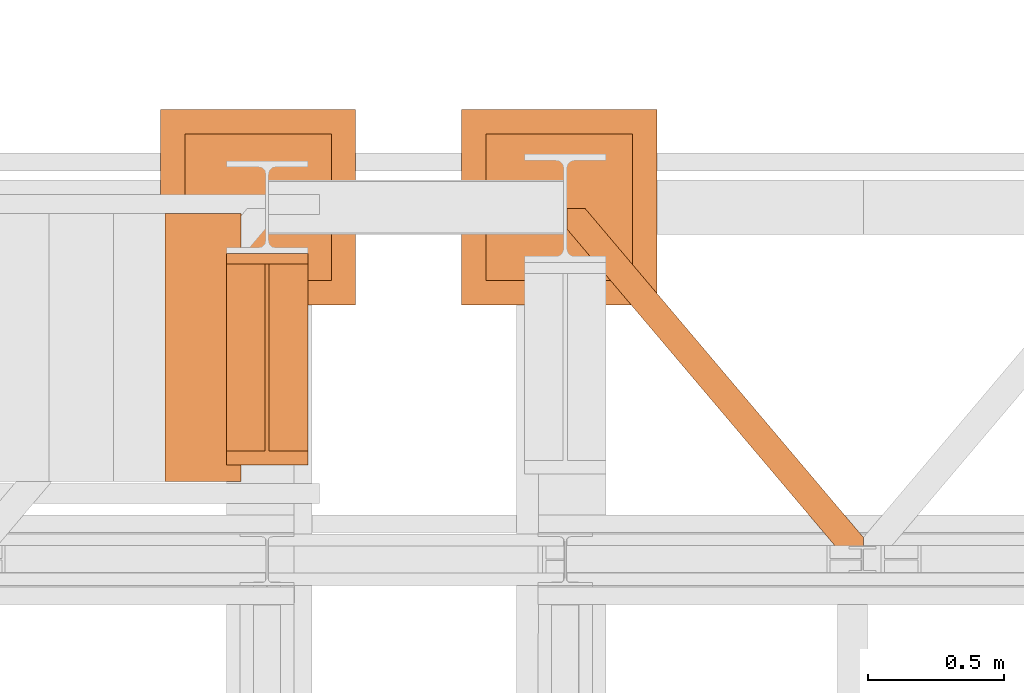
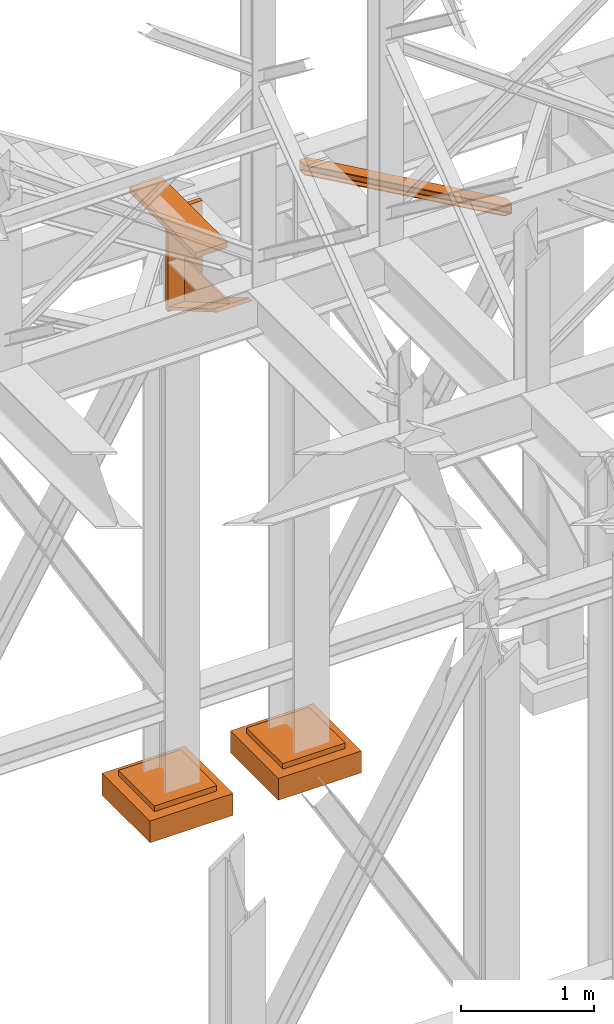
# One storey, part 137 of 208: 5 proxies.
"""IFC2X3 building model written with IfcOpenShell, lengths in millimetres."""

from ifc_helpers import new_model, entity, si_unit, converted_unit, frame, origin, origin_with_axes, place, context, subcontext, project, spatial, faceted_brep, element, save


model = new_model("IFC2X3")

# Units and contexts
model_context = context("Model", 3, precision=1e-05, world=origin())
plan_context = context("Plan", 3, precision=1e-05, world=origin())
body_context = subcontext(model_context, "Body", "Model", "MODEL_VIEW")
ifc_project = project(units=[si_unit("LENGTHUNIT", "METRE", prefix="MILLI"), converted_unit("PLANEANGLEUNIT", "DEGREE", entity("IfcPlaneAngleMeasure", 0.0174532925199433), si_unit("PLANEANGLEUNIT", "RADIAN"), dimensions=[0, 0, 0, 0, 0, 0, 0]), si_unit("AREAUNIT", "SQUARE_METRE"), si_unit("VOLUMEUNIT", "CUBIC_METRE")], contexts=[model_context, plan_context])

# Building, storey
building_placement = place(None, origin())
building = spatial("IfcBuilding", under=ifc_project, at=building_placement, CompositionType="COMPLEX")
storey_placement = place(building_placement, origin_with_axes())
storey = spatial("IfcBuildingStorey", under=building, at=storey_placement, Name="Geschoss", CompositionType="ELEMENT")

# Proxies
proxy_1_placement = place(storey_placement, frame((-1256.745037431798, -13412.43639531566, 4367.230005364415), z_axis=(0.0, 0.0, 1.0), x_axis=(1.0, 0.0, 0.0)))
element("IfcBuildingElementProxy", 1, at=proxy_1_placement, inside=storey, context=body_context, shape_type="Brep", body=[
    faceted_brep([(0.009999999999990905, 739.8720000000012, 18.61000000000058), (0.009999999999990905, 0.01000000000021828, 445.7700000000004), (300.01, 0.01000000000021828, 445.7700000000004), (300.01, 739.8720000000012, 18.61000000000058), (0.009999999999990905, 0.01000000000021828, 445.7700000000004), (0.009999999999990905, 50.06600000000071, 445.7710000000006), (142.51, 50.06600000000071, 445.7710000000006), (142.51, 739.8720000000012, 445.7700000000004), (157.51, 739.8720000000012, 445.7700000000004), (157.51, 50.06600000000071, 445.7710000000006), (300.01, 50.06600000000071, 445.7710000000006), (300.01, 0.01000000000021828, 445.7700000000004), (0.009999999999990905, 50.06600000000071, 445.7710000000006), (0.009999999999990905, 739.8720000000012, 47.51000000000022), (142.51, 739.8720000000012, 47.51000000000022), (142.51, 50.06600000000071, 445.7710000000006), (157.51, 739.8720000000012, 47.51000000000022), (300.01, 739.8720000000012, 47.51000000000022), (300.01, 50.06600000000071, 445.7710000000006), (157.51, 50.06600000000071, 445.7710000000006), (0.009999999999990905, 739.8720000000012, 18.61000000000058), (0.009999999999990905, 739.8720000000012, 0.01000000000021828), (0.009999999999990905, 779.8720000000012, 0.01000000000021828), (0.009999999999990905, 779.8720000000012, 917.7700000000013), (0.009999999999990905, 739.8720000000012, 917.7700000000013), (0.009999999999990905, 739.8720000000012, 47.51000000000022), (0.009999999999990905, 50.06600000000071, 445.7710000000006), (0.009999999999990905, 0.01000000000021828, 445.7700000000004), (300.01, 779.8719999999994, 917.7700000000013), (300.01, 779.8720000000012, 0.01000000000021828), (300.01, 739.8720000000012, 0.01000000000021828), (300.01, 739.8720000000012, 18.61000000000058), (300.01, 0.01000000000021828, 445.7700000000004), (300.01, 50.06600000000071, 445.7710000000006), (300.01, 739.8720000000012, 47.51000000000022), (300.01, 739.8719999999994, 917.7700000000013), (300.01, 779.8719999999994, 917.7700000000013), (300.01, 739.8719999999994, 917.7700000000013), (0.009999999999990905, 739.8720000000012, 917.7700000000013), (0.009999999999990905, 779.8720000000012, 917.7700000000013), (300.01, 739.8719999999994, 917.7700000000013), (300.01, 739.8720000000012, 47.51000000000022), (157.51, 739.8720000000012, 47.51000000000022), (157.51, 739.8720000000012, 445.7700000000004), (142.51, 739.8720000000012, 445.7700000000004), (142.51, 739.8720000000012, 47.51000000000022), (0.009999999999990905, 739.8720000000012, 47.51000000000022), (0.009999999999990905, 739.8720000000012, 917.7700000000013), (300.01, 739.8720000000012, 18.61000000000058), (300.01, 739.8720000000012, 0.01000000000021828), (0.009999999999990905, 739.8720000000012, 0.01000000000021828), (0.009999999999990905, 739.8720000000012, 18.61000000000058), (300.01, 739.8720000000012, 0.01000000000021828), (300.01, 779.8720000000012, 0.01000000000021828), (0.009999999999990905, 779.8720000000012, 0.01000000000021828), (0.009999999999990905, 739.8720000000012, 0.01000000000021828), (300.01, 779.8720000000012, 0.01000000000021828), (300.01, 779.8719999999994, 917.7700000000013), (0.009999999999990905, 779.8720000000012, 917.7700000000013), (0.009999999999990905, 779.8720000000012, 0.01000000000021828), (142.51, 739.8720000000012, 47.51000000000022), (142.51, 739.8720000000012, 445.7700000000004), (142.51, 50.06600000000071, 445.7710000000006), (157.51, 739.8720000000012, 47.51000000000022), (157.51, 50.06600000000071, 445.7710000000006), (157.51, 739.8720000000012, 445.7700000000004)], [[[0, 1, 2, 3]], [[4, 5, 6, 7, 8, 9, 10, 11]], [[12, 13, 14, 15]], [[16, 17, 18, 19]], [[20, 21, 22, 23, 24, 25, 26, 27]], [[28, 29, 30, 31, 32, 33, 34, 35]], [[36, 37, 38, 39]], [[40, 41, 42, 43, 44, 45, 46, 47]], [[48, 49, 50, 51]], [[52, 53, 54, 55]], [[56, 57, 58, 59]], [[60, 61, 62]], [[63, 64, 65]]], orient=[[False], [False], [False], [False], [False], [False], [False], [False], [False], [False], [False], [False], [False]]),
])
proxy_2_placement = place(storey_placement, frame((-0.7450314191753478, -13757.87439038569, 5101.990016164881), z_axis=(0.0, 0.0, 1.0), x_axis=(1.0, 0.0, 0.0)))
element("IfcBuildingElementProxy", 2, at=proxy_2_placement, inside=storey, context=body_context, shape_type="Brep", body=[
    faceted_brep([(1028.512359102908, 0.01000000000021828, 8.010001311302403), (1028.512359102908, 0.01000000000021828, 0.01000000000021828), (0.009999999999990905, 1215.51278803071, 0.01000000000021828), (0.009999999999990905, 1215.51278803071, 8.010001311303313), (1028.512359102908, 0.01000000000021828, 0.01000000000021828), (1094.009999947844, 0.01000000000021828, 0.01000000000021828), (1094.009999947844, 77.41630281674588, 0.01000000000021828), (67.46148411605259, 1290.610003345229, 0.01000000000021828), (0.009999999999990905, 1290.610003345229, 0.01000000000021828), (0.009999999999990905, 1215.51278803071, 0.01000000000021828), (1094.009999947844, 77.41630281674588, 0.01000000000021828), (1094.009999947846, 77.41630281674406, 8.010001311302403), (67.46148411605259, 1290.610003345229, 8.010001311302403), (67.46148411605259, 1290.610003345229, 0.01000000000021828), (1094.009999947846, 77.41630281674406, 8.010001311302403), (1094.009999947844, 22.45782827823314, 8.010001311302403), (20.95815950654264, 1290.610003345229, 8.010001311302403), (67.46148411605259, 1290.610003345229, 8.010001311302403), (1094.009999947844, 22.45782827823314, 8.010001311302403), (1094.009999947845, 12.84312897135715, 9.253033826351384), (12.82264470841778, 1290.610003345229, 9.253033826351384), (20.95815950654264, 1290.610003345229, 8.010001311302403), (1094.009999947845, 12.84312897135715, 9.253033826351384), (1094.009999947845, 5.804685632951077, 13.79946006298087), (6.867038806687333, 1290.610003345229, 13.79946006298087), (12.82264470841778, 1290.610003345229, 9.253033826351384), (1094.009999947845, 5.804685632951077, 13.79946006298087), (1094.009999947844, 3.880315357107975, 20.01000141561053), (5.238725496361212, 1290.610003345229, 20.01000141560962), (6.867038806687333, 1290.610003345229, 13.79946006298087), (1094.009999947844, 3.880315357107975, 20.01000141561053), (1094.009999947844, 3.880315357111613, 76.01000128150008), (5.238725496361212, 1290.610003345229, 76.01000128150008), (5.238725496361212, 1290.610003345229, 20.01000141560962), (1094.009999947844, 3.880315357111613, 76.01000128150008), (1094.009999947845, 5.804685632951077, 82.2205407714846), (6.867038806687333, 1290.610003345229, 82.2205407714846), (5.238725496361212, 1290.610003345229, 76.01000128150008), (1094.009999947845, 5.804685632951077, 82.2205407714846), (1094.009999947845, 12.84312897135715, 86.76696700811408), (12.82264470841778, 1290.610003345229, 86.76696700811317), (6.867038806687333, 1290.610003345229, 82.2205407714846), (1094.009999947845, 12.84312897135715, 86.76696700811408), (1094.009999947845, 22.45782827823314, 88.00999952316306), (20.95815950654446, 1290.610003345229, 88.00999952316306), (12.82264470841778, 1290.610003345229, 86.76696700811317), (1094.009999947845, 22.45782827823314, 88.00999952316306), (1094.009999947845, 77.41630281674588, 88.00999952316306), (67.46148411605259, 1290.610003345229, 88.00999952316397), (20.95815950654446, 1290.610003345229, 88.00999952316306), (1094.009999947845, 77.41630281674588, 88.00999952316306), (1094.009999947847, 77.41630281674406, 96.01000083446525), (67.46148411605259, 1290.610003345229, 96.01000083446525), (67.46148411605259, 1290.610003345229, 88.00999952316397), (1094.009999947847, 77.41630281674406, 96.01000083446525), (1094.009999947846, 0.01000000000021828, 96.01000083446525), (1028.512359102909, 0.01000000000021828, 96.01000083446525), (0.009999999999990905, 1215.51278803071, 96.01000083446525), (0.009999999999990905, 1290.610003345229, 96.01000083446525), (67.46148411605259, 1290.610003345229, 96.01000083446525), (1028.512359102909, 0.01000000000021828, 96.01000083446525), (1028.512359102909, 0.01000000000021828, 88.00999952316306), (0.009999999999990905, 1215.51278803071, 88.00999952316306), (0.009999999999990905, 1215.51278803071, 96.01000083446525), (1028.512359102909, 0.01000000000021828, 88.00999952316306), (1075.015683712419, 0.01000000000021828, 88.00999952316306), (0.009999999999990905, 1270.471262569223, 88.00999952316215), (0.009999999999990905, 1215.51278803071, 88.00999952316306), (1075.015683712419, 0.01000000000021828, 88.00999952316306), (1083.151198510545, 0.01000000000021828, 86.76696700811408), (0.009999999999990905, 1280.085961876101, 86.76696700811499), (0.009999999999990905, 1270.471262569223, 88.00999952316215), (1083.151198510545, 0.01000000000021828, 86.76696700811408), (1089.106804412274, 0.01000000000021828, 82.2205407714846), (0.009999999999990905, 1287.124405214507, 82.2205407714855), (0.009999999999990905, 1280.085961876101, 86.76696700811499), (1089.106804412274, 0.01000000000021828, 82.2205407714846), (1090.735117722602, 0.01000000000021828, 76.01000128150008), (0.009999999999990905, 1289.04877549035, 76.01000128150008), (0.009999999999990905, 1287.124405214507, 82.2205407714855), (1090.735117722602, 0.01000000000021828, 76.01000128150008), (1090.735117722601, 0.01000000000021828, 20.01000141561053), (0.009999999999990905, 1289.048775490348, 20.01000141561053), (0.009999999999990905, 1289.04877549035, 76.01000128150008), (1090.735117722601, 0.01000000000021828, 20.01000141561053), (1089.106804412275, 0.01000000000021828, 13.79946006298087), (0.009999999999990905, 1287.124405214507, 13.79946006298087), (0.009999999999990905, 1289.048775490348, 20.01000141561053), (1089.106804412275, 0.01000000000021828, 13.79946006298087), (1083.151198510544, 0.01000000000021828, 9.253033826351384), (0.009999999999990905, 1280.085961876099, 9.253033826351384), (0.009999999999990905, 1287.124405214507, 13.79946006298087), (1083.151198510544, 0.01000000000021828, 9.253033826351384), (1075.015683712418, 0.01000000000021828, 8.010001311302403), (0.009999999999990905, 1270.471262569225, 8.010001311302403), (0.009999999999990905, 1280.085961876099, 9.253033826351384), (1075.015683712418, 0.01000000000021828, 8.010001311302403), (1028.512359102908, 0.01000000000021828, 8.010001311302403), (0.009999999999990905, 1215.51278803071, 8.010001311303313), (0.009999999999990905, 1270.471262569225, 8.010001311302403), (1094.009999947844, 77.41630281674588, 0.01000000000021828), (1094.009999947844, 0.01000000000021828, 0.01000000000021828), (1094.009999947846, 0.01000000000021828, 96.01000083446525), (1094.009999947847, 77.41630281674406, 96.01000083446525), (1094.009999947845, 77.41630281674588, 88.00999952316306), (1094.009999947845, 22.45782827823314, 88.00999952316306), (1094.009999947845, 12.84312897135715, 86.76696700811408), (1094.009999947845, 5.804685632951077, 82.2205407714846), (1094.009999947844, 3.880315357111613, 76.01000128150008), (1094.009999947844, 3.880315357107975, 20.01000141561053), (1094.009999947845, 5.804685632951077, 13.79946006298087), (1094.009999947845, 12.84312897135715, 9.253033826351384), (1094.009999947844, 22.45782827823314, 8.010001311302403), (1094.009999947846, 77.41630281674406, 8.010001311302403), (1094.009999947846, 0.01000000000021828, 96.01000083446525), (1094.009999947844, 0.01000000000021828, 0.01000000000021828), (1028.512359102908, 0.01000000000021828, 0.01000000000021828), (1028.512359102908, 0.01000000000021828, 8.010001311302403), (1075.015683712418, 0.01000000000021828, 8.010001311302403), (1083.151198510544, 0.01000000000021828, 9.253033826351384), (1089.106804412275, 0.01000000000021828, 13.79946006298087), (1090.735117722601, 0.01000000000021828, 20.01000141561053), (1090.735117722602, 0.01000000000021828, 76.01000128150008), (1089.106804412274, 0.01000000000021828, 82.2205407714846), (1083.151198510545, 0.01000000000021828, 86.76696700811408), (1075.015683712419, 0.01000000000021828, 88.00999952316306), (1028.512359102909, 0.01000000000021828, 88.00999952316306), (1028.512359102909, 0.01000000000021828, 96.01000083446525), (0.009999999999990905, 1215.51278803071, 0.01000000000021828), (0.009999999999990905, 1290.610003345229, 0.01000000000021828), (0.009999999999990905, 1290.610003345229, 96.01000083446525), (0.009999999999990905, 1215.51278803071, 96.01000083446525), (0.009999999999990905, 1215.51278803071, 88.00999952316306), (0.009999999999990905, 1270.471262569223, 88.00999952316215), (0.009999999999990905, 1280.085961876101, 86.76696700811499), (0.009999999999990905, 1287.124405214507, 82.2205407714855), (0.009999999999990905, 1289.04877549035, 76.01000128150008), (0.009999999999990905, 1289.048775490348, 20.01000141561053), (0.009999999999990905, 1287.124405214507, 13.79946006298087), (0.009999999999990905, 1280.085961876099, 9.253033826351384), (0.009999999999990905, 1270.471262569225, 8.010001311302403), (0.009999999999990905, 1215.51278803071, 8.010001311303313), (67.46148411605259, 1290.610003345229, 0.01000000000021828), (67.46148411605259, 1290.610003345229, 8.010001311302403), (20.95815950654264, 1290.610003345229, 8.010001311302403), (12.82264470841778, 1290.610003345229, 9.253033826351384), (6.867038806687333, 1290.610003345229, 13.79946006298087), (5.238725496361212, 1290.610003345229, 20.01000141560962), (5.238725496361212, 1290.610003345229, 76.01000128150008), (6.867038806687333, 1290.610003345229, 82.2205407714846), (12.82264470841778, 1290.610003345229, 86.76696700811317), (20.95815950654446, 1290.610003345229, 88.00999952316306), (67.46148411605259, 1290.610003345229, 88.00999952316397), (67.46148411605259, 1290.610003345229, 96.01000083446525), (0.009999999999990905, 1290.610003345229, 96.01000083446525), (0.009999999999990905, 1290.610003345229, 0.01000000000021828)], [[[0, 1, 2, 3]], [[4, 5, 6, 7, 8, 9]], [[10, 11, 12, 13]], [[14, 15, 16, 17]], [[18, 19, 20, 21]], [[22, 23, 24, 25]], [[26, 27, 28, 29]], [[30, 31, 32, 33]], [[34, 35, 36, 37]], [[38, 39, 40, 41]], [[42, 43, 44, 45]], [[46, 47, 48, 49]], [[50, 51, 52, 53]], [[54, 55, 56, 57, 58, 59]], [[60, 61, 62, 63]], [[64, 65, 66, 67]], [[68, 69, 70, 71]], [[72, 73, 74, 75]], [[76, 77, 78, 79]], [[80, 81, 82, 83]], [[84, 85, 86, 87]], [[88, 89, 90, 91]], [[92, 93, 94, 95]], [[96, 97, 98, 99]], [[100, 101, 102, 103, 104, 105, 106, 107, 108, 109, 110, 111, 112, 113]], [[114, 115, 116, 117, 118, 119, 120, 121, 122, 123, 124, 125, 126, 127]], [[128, 129, 130, 131, 132, 133, 134, 135, 136, 137, 138, 139, 140, 141]], [[142, 143, 144, 145, 146, 147, 148, 149, 150, 151, 152, 153, 154, 155]]], orient=[[False], [False], [False], [False], [False], [False], [False], [False], [False], [False], [False], [False], [False], [False], [False], [False], [False], [False], [False], [False], [False], [False], [False], [False], [False], [False], [False], [False]]),
])
proxy_3_placement = place(storey_placement, frame((-388.6908527149269, -12822.57439725281, -315.01), z_axis=(0.0, 0.0, 1.0), x_axis=(1.0, 0.0, 0.0)))
element("IfcBuildingElementProxy", 3, at=proxy_3_placement, inside=storey, context=body_context, shape_type="Brep", body=[
    faceted_brep([(630.01, 630.0100000000002, 250.01), (630.01, 90.01000000000022, 250.01), (90.00999999999999, 90.01000000000022, 250.01), (90.00999999999999, 630.0100000000002, 250.01), (630.01, 630.0100000000002, 200.01), (630.01, 90.01000000000022, 200.01), (630.01, 90.01000000000022, 250.01), (630.01, 630.0100000000002, 250.01), (90.00999999999999, 630.0100000000002, 200.01), (630.01, 630.0100000000002, 200.01), (630.01, 630.0100000000002, 250.01), (90.00999999999999, 630.0100000000002, 250.01), (90.00999999999999, 90.01000000000022, 200.01), (90.00999999999999, 630.0100000000002, 200.01), (90.00999999999999, 630.0100000000002, 250.01), (90.00999999999999, 90.01000000000022, 250.01), (630.01, 90.01000000000022, 200.01), (90.00999999999999, 90.01000000000022, 200.01), (90.00999999999999, 90.01000000000022, 250.01), (630.01, 90.01000000000022, 250.01), (720.01, 0.01000000000021828, 0.009999999999990905), (720.01, 720.0100000000002, 0.009999999999990905), (0.009999999999990905, 720.0100000000002, 0.009999999999990905), (0.009999999999990905, 0.01000000000021828, 0.009999999999990905), (720.01, 720.0100000000002, 200.01), (720.01, 0.01000000000021828, 200.01), (0.009999999999990905, 0.01000000000021828, 200.01), (0.009999999999990905, 720.0100000000002, 200.01), (90.00999999999999, 90.01000000000022, 200.01), (630.01, 90.01000000000022, 200.01), (630.01, 630.0100000000002, 200.01), (90.00999999999999, 630.0100000000002, 200.01), (720.01, 720.0100000000002, 0.009999999999990905), (720.01, 0.01000000000021828, 0.009999999999990905), (720.01, 0.01000000000021828, 200.01), (720.01, 720.0100000000002, 200.01), (0.009999999999990905, 720.0100000000002, 0.009999999999990905), (720.01, 720.0100000000002, 0.009999999999990905), (720.01, 720.0100000000002, 200.01), (0.009999999999990905, 720.0100000000002, 200.01), (0.009999999999990905, 0.01000000000021828, 0.009999999999990905), (0.009999999999990905, 720.0100000000002, 0.009999999999990905), (0.009999999999990905, 720.0100000000002, 200.01), (0.009999999999990905, 0.01000000000021828, 200.01), (720.01, 0.01000000000021828, 0.009999999999990905), (0.009999999999990905, 0.01000000000021828, 0.009999999999990905), (0.009999999999990905, 0.01000000000021828, 200.01), (720.01, 0.01000000000021828, 200.01)], [[[0, 1, 2, 3]], [[4, 5, 6, 7]], [[8, 9, 10, 11]], [[12, 13, 14, 15]], [[16, 17, 18, 19]], [[20, 21, 22, 23]], [[24, 25, 26, 27], [28, 29, 30, 31]], [[32, 33, 34, 35]], [[36, 37, 38, 39]], [[40, 41, 42, 43]], [[44, 45, 46, 47]]], orient=[[False], [False], [False], [False], [False], [False], [False, False], [False], [False], [False], [False]]),
])
proxy_4_placement = place(storey_placement, frame((-1499.794506223426, -12822.57439725281, -315.0099999999999), z_axis=(0.0, 0.0, 1.0), x_axis=(1.0, 0.0, 0.0)))
element("IfcBuildingElementProxy", 4, at=proxy_4_placement, inside=storey, context=body_context, shape_type="Brep", body=[
    faceted_brep([(630.01, 630.0100000000002, 250.01), (630.01, 90.01000000000022, 250.01), (90.00999999999999, 90.01000000000022, 250.01), (90.00999999999999, 630.0100000000002, 250.01), (630.01, 630.0100000000002, 200.01), (630.01, 90.01000000000022, 200.01), (630.01, 90.01000000000022, 250.01), (630.01, 630.0100000000002, 250.01), (90.00999999999999, 630.0100000000002, 200.01), (630.01, 630.0100000000002, 200.01), (630.01, 630.0100000000002, 250.01), (90.00999999999999, 630.0100000000002, 250.01), (90.00999999999999, 90.01000000000022, 200.01), (90.00999999999999, 630.0100000000002, 200.01), (90.00999999999999, 630.0100000000002, 250.01), (90.00999999999999, 90.01000000000022, 250.01), (630.01, 90.01000000000022, 200.01), (90.00999999999999, 90.01000000000022, 200.01), (90.00999999999999, 90.01000000000022, 250.01), (630.01, 90.01000000000022, 250.01), (720.01, 0.01000000000021828, 0.009999999999990905), (720.01, 720.0100000000002, 0.009999999999990905), (0.009999999999990905, 720.0100000000002, 0.009999999999990905), (0.009999999999990905, 0.01000000000021828, 0.009999999999990905), (720.01, 720.0100000000002, 200.01), (720.01, 0.01000000000021828, 200.01), (0.009999999999990905, 0.01000000000021828, 200.01), (0.009999999999990905, 720.0100000000002, 200.01), (90.00999999999999, 90.01000000000022, 200.01), (630.01, 90.01000000000022, 200.01), (630.01, 630.0100000000002, 200.01), (90.00999999999999, 630.0100000000002, 200.01), (720.01, 720.0100000000002, 0.009999999999990905), (720.01, 0.01000000000021828, 0.009999999999990905), (720.01, 0.01000000000021828, 200.01), (720.01, 720.0100000000002, 200.01), (0.009999999999990905, 720.0100000000002, 0.009999999999990905), (720.01, 720.0100000000002, 0.009999999999990905), (720.01, 720.0100000000002, 200.01), (0.009999999999990905, 720.0100000000002, 200.01), (0.009999999999990905, 0.01000000000021828, 0.009999999999990905), (0.009999999999990905, 720.0100000000002, 0.009999999999990905), (0.009999999999990905, 720.0100000000002, 200.01), (0.009999999999990905, 0.01000000000021828, 200.01), (720.01, 0.01000000000021828, 0.009999999999990905), (0.009999999999990905, 0.01000000000021828, 0.009999999999990905), (0.009999999999990905, 0.01000000000021828, 200.01), (720.01, 0.01000000000021828, 200.01)], [[[0, 1, 2, 3]], [[4, 5, 6, 7]], [[8, 9, 10, 11]], [[12, 13, 14, 15]], [[16, 17, 18, 19]], [[20, 21, 22, 23]], [[24, 25, 26, 27], [28, 29, 30, 31]], [[32, 33, 34, 35]], [[36, 37, 38, 39]], [[40, 41, 42, 43]], [[44, 45, 46, 47]]], orient=[[False], [False], [False], [False], [False], [False], [False, False], [False], [False], [False], [False]]),
])
proxy_5_placement = place(storey_placement, frame((-1483.793599482342, -13474.7262510599, 5425.907862574692), z_axis=(0.0, 0.0, 1.0), x_axis=(1.0, 0.0, 0.0)))
element("IfcBuildingElementProxy", 5, at=proxy_5_placement, inside=storey, context=body_context, shape_type="Brep", body=[
    faceted_brep([(0.009999999999990905, 0.01000000000021828, 0.01000000000021828), (280.2746556316176, 0.01000000000021828, 0.01000000000021828), (280.2746556316176, 988.9080206708586, 0.01000000000021828), (0.009999999999990905, 988.9080206708586, 0.01000000000021828), (280.2746556316176, 0.01000000000021828, 50.01000000000022), (0.009999999999990905, 0.01000000000021828, 50.01000000000022), (0.009999999999990905, 988.9080206708586, 50.01000000000022), (280.2746556316176, 988.9080206708586, 50.01000000000022), (280.2746556316176, 0.01000000000021828, 0.01000000000021828), (0.009999999999990905, 0.01000000000021828, 0.01000000000021828), (0.009999999999990905, 0.01000000000021828, 50.01000000000022), (280.2746556316176, 0.01000000000021828, 50.01000000000022), (280.2746556316176, 988.9080206708586, 0.01000000000021828), (280.2746556316176, 0.01000000000021828, 0.01000000000021828), (280.2746556316176, 0.01000000000021828, 50.01000000000022), (280.2746556316176, 988.9080206708586, 50.01000000000022), (0.009999999999990905, 988.9080206708586, 0.01000000000021828), (280.2746556316176, 988.9080206708586, 0.01000000000021828), (280.2746556316176, 988.9080206708586, 50.01000000000022), (0.009999999999990905, 988.9080206708586, 50.01000000000022), (0.009999999999990905, 0.01000000000021828, 0.01000000000021828), (0.009999999999990905, 988.9080206708586, 0.01000000000021828), (0.009999999999990905, 988.9080206708586, 50.01000000000022), (0.009999999999990905, 0.01000000000021828, 50.01000000000022)], [[[0, 1, 2, 3]], [[4, 5, 6, 7]], [[8, 9, 10, 11]], [[12, 13, 14, 15]], [[16, 17, 18, 19]], [[20, 21, 22, 23]]], orient=[[False], [False], [False], [False], [False], [False]]),
])

save(model, "model.ifc")
